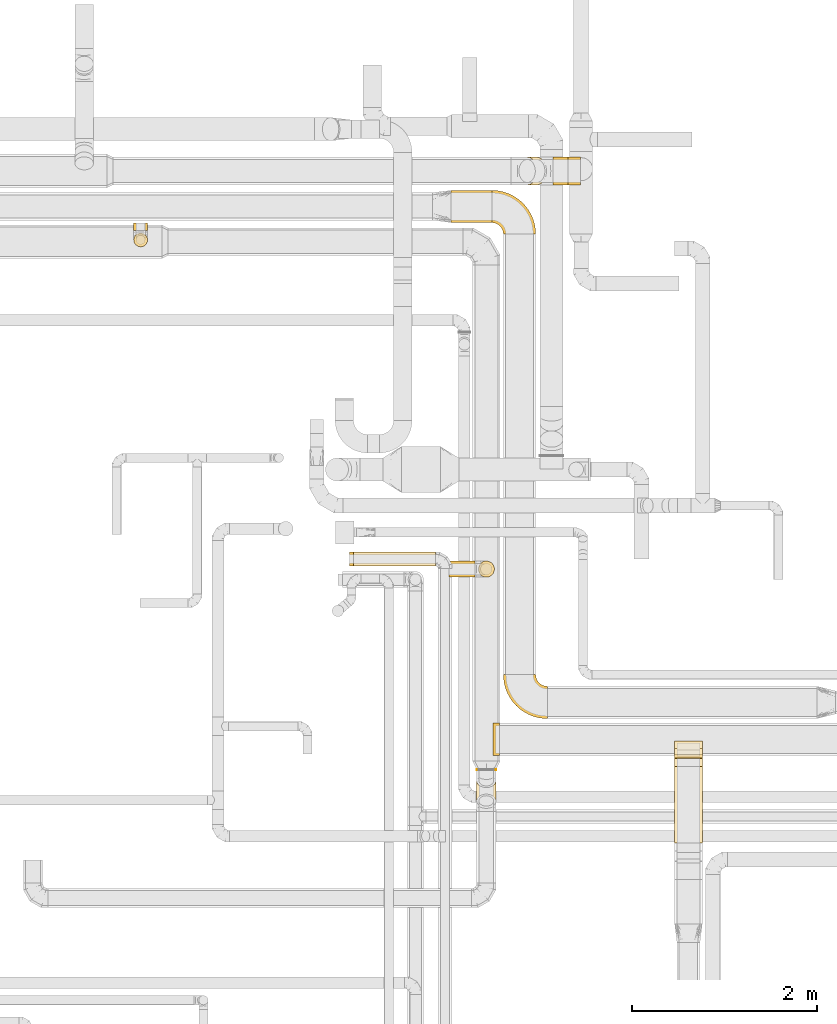
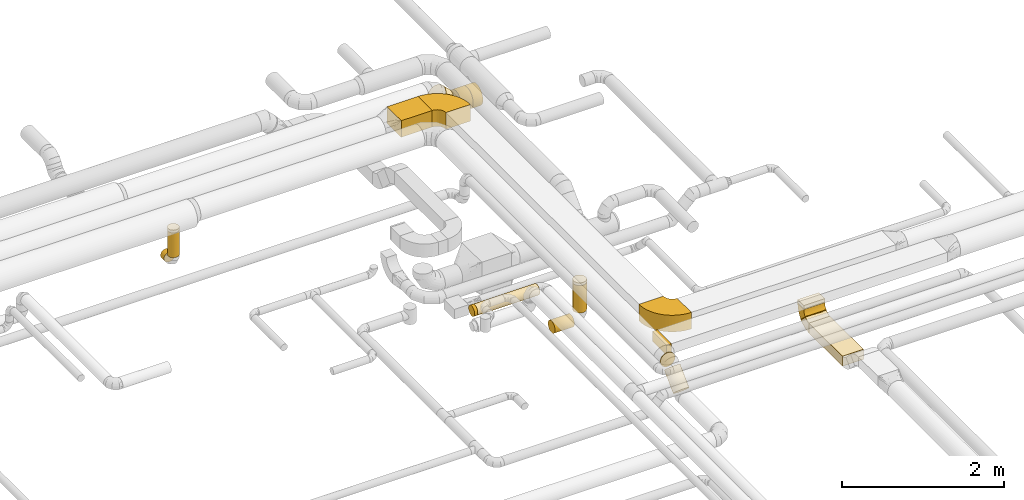
# One storey, part 5 of 92: 23 coverings.
"""IFC2X3 building model written with IfcOpenShell, lengths in millimetres."""

from ifc_helpers import new_model, entity, si_unit, converted_unit, derived_unit, direction, frame, frame_2d, origin, origin_2d_with_axis, place, context, subcontext, project, spatial, polyline, circle_curve, parameter, trimmed, segment, composite_curve, rectangle, circle, outline, extrude, element, save


model = new_model("IFC2X3")

# Units and contexts
model_context = context("Model", 3, precision=0.01, world=origin(), true_north=direction((6.12303176911189e-17, 1.0)))
body_context = subcontext(model_context, "Body", "Model", "MODEL_VIEW")
ifc_project = project(units=[si_unit("LENGTHUNIT", "METRE", prefix="MILLI"), si_unit("AREAUNIT", "SQUARE_METRE"), si_unit("VOLUMEUNIT", "CUBIC_METRE"), converted_unit("PLANEANGLEUNIT", "DEGREE", entity("IfcRatioMeasure", 0.0174532925199433), si_unit("PLANEANGLEUNIT", "RADIAN"), dimensions=[0, 0, 0, 0, 0, 0, 0]), si_unit("MASSUNIT", "GRAM", prefix="KILO"), derived_unit("MASSDENSITYUNIT", [(si_unit("MASSUNIT", "GRAM", prefix="KILO"), 1), (si_unit("LENGTHUNIT", "METRE"), -3)]), derived_unit("MOMENTOFINERTIAUNIT", [(si_unit("LENGTHUNIT", "METRE"), 4)]), si_unit("TIMEUNIT", "SECOND"), si_unit("FREQUENCYUNIT", "HERTZ"), si_unit("THERMODYNAMICTEMPERATUREUNIT", "DEGREE_CELSIUS"), derived_unit("THERMALTRANSMITTANCEUNIT", [(si_unit("MASSUNIT", "GRAM", prefix="KILO"), 1), (si_unit("THERMODYNAMICTEMPERATUREUNIT", "KELVIN"), -1), (si_unit("TIMEUNIT", "SECOND"), -3)]), derived_unit("VOLUMETRICFLOWRATEUNIT", [(si_unit("LENGTHUNIT", "METRE"), 3), (si_unit("TIMEUNIT", "SECOND"), -1)]), derived_unit("MASSFLOWRATEUNIT", [(si_unit("MASSUNIT", "GRAM", prefix="KILO"), 1), (si_unit("TIMEUNIT", "SECOND"), -1)]), derived_unit("ROTATIONALFREQUENCYUNIT", [(si_unit("TIMEUNIT", "SECOND"), -1)]), si_unit("ELECTRICCURRENTUNIT", "AMPERE"), si_unit("ELECTRICVOLTAGEUNIT", "VOLT"), si_unit("POWERUNIT", "WATT"), si_unit("FORCEUNIT", "NEWTON", prefix="KILO"), si_unit("ILLUMINANCEUNIT", "LUX"), si_unit("LUMINOUSFLUXUNIT", "LUMEN"), si_unit("LUMINOUSINTENSITYUNIT", "CANDELA"), derived_unit("USERDEFINED", [(si_unit("MASSUNIT", "GRAM", prefix="KILO"), -1), (si_unit("LENGTHUNIT", "METRE"), -2), (si_unit("TIMEUNIT", "SECOND"), 3), (si_unit("LUMINOUSFLUXUNIT", "LUMEN"), 1)]), derived_unit("LINEARVELOCITYUNIT", [(si_unit("LENGTHUNIT", "METRE"), 1), (si_unit("TIMEUNIT", "SECOND"), -1)]), si_unit("PRESSUREUNIT", "PASCAL"), derived_unit("USERDEFINED", [(si_unit("LENGTHUNIT", "METRE"), -2), (si_unit("MASSUNIT", "GRAM", prefix="KILO"), 1), (si_unit("TIMEUNIT", "SECOND"), -2)]), derived_unit("LINEARFORCEUNIT", [(si_unit("MASSUNIT", "GRAM", prefix="KILO"), 1), (si_unit("LENGTHUNIT", "METRE"), 1), (si_unit("TIMEUNIT", "SECOND"), -2), (si_unit("LENGTHUNIT", "METRE"), -1)]), derived_unit("PLANARFORCEUNIT", [(si_unit("MASSUNIT", "GRAM", prefix="KILO"), 1), (si_unit("LENGTHUNIT", "METRE"), 1), (si_unit("TIMEUNIT", "SECOND"), -2), (si_unit("LENGTHUNIT", "METRE"), -2)])], contexts=[model_context])

# Site, building, storey
site_placement = place(None, origin())
site = spatial("IfcSite", under=ifc_project, at=site_placement, CompositionType="ELEMENT")
building_placement = place(site_placement, origin())
building = spatial("IfcBuilding", under=site, at=building_placement, CompositionType="ELEMENT")
storey_placement = place(building_placement, frame((0.0, 0.0, 4200.0)))
storey = spatial("IfcBuildingStorey", under=building, at=storey_placement, CompositionType="ELEMENT", Elevation=4200.0)

# Coverings
covering_1_placement = place(storey_placement, frame((60704.33, 15163.51, 3175.0)))
element("IfcCovering", 1, at=covering_1_placement, inside=storey, PredefinedType="INSULATION", context=body_context, shape_type="SweptSolid", body=[
    extrude(rectangle(XDim=440.000000000013, YDim=349.999999999998, at=origin_2d_with_axis()), frame((220.0, 175.0, 0.0), z_axis=(0.0, 0.0, 1.0), x_axis=(-1.0, 0.0, 0.0)), (0.0, 0.0, 1.0), 249.999999999999),
])
covering_2_placement = place(storey_placement, frame((61806.89, 15570.41, 2848.4)))
element("IfcCovering", 2, at=covering_2_placement, inside=storey, PredefinedType="INSULATION", context=body_context, shape_type="SweptSolid", body=[
    extrude(circle(Radius=150.0, at=origin_2d_with_axis()), frame((0.0, 151.6, 151.6), z_axis=(1.0, 0.0, 0.0), x_axis=(0.0, -1.0, 0.0)), (0.0, 0.0, 1.0), 159.717263995072),
])
covering_3_placement = place(storey_placement, frame((61418.9, 15570.41, 2965.56)))
element("IfcCovering", 3, at=covering_3_placement, inside=storey, PredefinedType="INSULATION", context=body_context, shape_type="SweptSolid", body=[
    extrude(circle(Radius=150.0, at=origin_2d_with_axis()), frame((107.66, 151.6, 211.21), z_axis=(0.707106445676234, 0.0, -0.707107116696702), x_axis=(0.0, 1.0, 0.0)), (0.0, 0.0, 1.0), 146.446302678894),
])
covering_4_placement = place(storey_placement, frame((61966.61, 15570.41, 2848.4)))
element("IfcCovering", 4, at=covering_4_placement, inside=storey, PredefinedType="INSULATION", context=body_context, shape_type="SweptSolid", body=[
    extrude(circle(Radius=150.0, at=origin_2d_with_axis()), frame((0.0, 151.6, 151.6), z_axis=(1.0, 0.0, 0.0), x_axis=(0.0, 0.0, -1.0)), (0.0, 0.0, 1.0), 138.903999999999),
])
covering_5_placement = place(storey_placement, frame((57270.37, 15077.0, 2523.4)))
element("IfcCovering", 5, at=covering_5_placement, inside=storey, PredefinedType="INSULATION", context=body_context, shape_type="SweptSolid", body=[
    extrude(circle(Radius=75.0, at=origin_2d_with_axis()), frame((76.6, 0.0, 76.6), z_axis=(0.0, 1.0, 0.0), x_axis=(-1.0, 0.0, 0.0)), (0.0, 0.0, 1.0), 84.9999999999027),
])
covering_6_placement = place(storey_placement, frame((60683.72, 11327.66, 2510.9)))
element("IfcCovering", 6, at=covering_6_placement, inside=storey, PredefinedType="INSULATION", context=body_context, shape_type="SweptSolid", body=[
    extrude(circle(Radius=87.5, at=origin_2d_with_axis()), frame((0.0, 89.1, 89.1), z_axis=(1.0, 0.0, 0.0), x_axis=(0.0, 1.0, 0.0)), (0.0, 0.0, 1.0), 276.27551312413),
])
covering_7_placement = place(storey_placement, frame((60995.9, 11327.66, 2725.0)))
element("IfcCovering", 7, at=covering_7_placement, inside=storey, PredefinedType="INSULATION", context=body_context, shape_type="SweptSolid", body=[
    extrude(circle(Radius=87.5, at=origin_2d_with_axis()), frame((89.1, 89.1, 0.0), z_axis=(0.0, 0.0, 1.0), x_axis=(0.0, 1.0, 0.0)), (0.0, 0.0, 1.0), 412.500000000017),
])
covering_8_placement = place(storey_placement, frame((60995.9, 11327.66, 3137.5)))
element("IfcCovering", 8, at=covering_8_placement, inside=storey, PredefinedType="INSULATION", context=body_context, shape_type="SweptSolid", body=[
    extrude(circle(Radius=87.5, at=origin_2d_with_axis()), frame((89.1, 89.1, 0.0), z_axis=(0.0, 0.0, 1.0), x_axis=(0.0, 1.0, 0.0)), (0.0, 0.0, 1.0), 42.8428245269404),
])
covering_9_placement = place(storey_placement, frame((61159.11, 9400.17, 3225.0)))
element("IfcCovering", 9, at=covering_9_placement, inside=storey, PredefinedType="INSULATION", context=body_context, shape_type="SweptSolid", body=[
    extrude(rectangle(XDim=69.6568108823519, YDim=349.999999999999, at=origin_2d_with_axis()), frame((34.83, 175.0, 0.0), z_axis=(0.0, 0.0, 1.0), x_axis=(-1.0, 0.0, 0.0)), (0.0, 0.0, 1.0), 150.000000000001),
])
covering_10_placement = place(storey_placement, frame((57270.37, 14900.4, 2700.0)))
element("IfcCovering", 10, at=covering_10_placement, inside=storey, PredefinedType="INSULATION", context=body_context, shape_type="SweptSolid", body=[
    extrude(circle(Radius=75.0, at=origin_2d_with_axis()), frame((76.6, 76.6, 0.0), z_axis=(0.0, 0.0, 1.0), x_axis=(-1.0, 0.0, 0.0)), (0.0, 0.0, 1.0), 373.77500200031),
])
covering_11_placement = place(storey_placement, frame((63121.35, 8456.55, 2945.0)))
element("IfcCovering", 11, at=covering_11_placement, inside=storey, PredefinedType="INSULATION", context=body_context, shape_type="SweptSolid", body=[
    extrude(rectangle(XDim=825.783728094219, YDim=300.000000000001, at=origin_2d_with_axis()), frame((150.0, 412.89, 0.0), z_axis=(0.0, 0.0, 1.0), x_axis=(0.0, 1.0, 0.0)), (0.0, 0.0, 1.0), 150.000000000001),
])
covering_12_placement = place(storey_placement, frame((60978.4, 9241.69, 3175.9)))
element("IfcCovering", 12, at=covering_12_placement, inside=storey, PredefinedType="INSULATION", context=body_context, shape_type="SweptSolid", body=[
    extrude(circle(Radius=105.0, at=origin_2d_with_axis()), frame((106.6, 0.0, 106.6), z_axis=(0.0, 1.0, 0.0), x_axis=(1.0, 0.0, 0.0)), (0.0, 0.0, 1.0), 9.44565002031431),
])
covering_13_placement = place(storey_placement, frame((60978.4, 8833.94, 2941.02)))
element("IfcCovering", 13, at=covering_13_placement, inside=storey, PredefinedType="INSULATION", context=body_context, shape_type="SweptSolid", body=[
    extrude(circle(Radius=105.0, at=origin_2d_with_axis()), frame((106.6, 75.84, 75.84), z_axis=(0.0, 0.707106781186505, 0.707106781186591), x_axis=(1.0, 0.0, 0.0)), (0.0, 0.0, 1.0), 309.393398282201),
])
covering_14_placement = place(storey_placement, frame((63121.35, 9410.17, 3222.84)))
element("IfcCovering", 14, at=covering_14_placement, inside=storey, PredefinedType="INSULATION", context=body_context, shape_type="SweptSolid", body=[
    extrude(rectangle(XDim=300.000000000001, YDim=150.000000000001, at=origin_2d_with_axis()), frame((150.0, 75.0, 0.0), z_axis=(0.0, 0.0, 1.0), x_axis=(-1.0, 0.0, 0.0)), (0.0, 0.0, 1.0), 7.15728752542948),
])
covering_15_placement = place(storey_placement, frame((63121.35, 9410.17, 3230.0)))
element("IfcCovering", 15, at=covering_15_placement, inside=storey, PredefinedType="INSULATION", context=body_context, shape_type="SweptSolid", body=[
    extrude(rectangle(XDim=150.000000000001, YDim=300.000000000001, at=origin_2d_with_axis()), frame((150.0, 75.0, 0.0), z_axis=(0.0, 0.0, 1.0), x_axis=(0.0, -1.0, 0.0)), (0.0, 0.0, 1.0), 51.0960000000005),
])
covering_16_placement = place(storey_placement, frame((63121.35, 9370.72, 3025.55)))
element("IfcCovering", 16, at=covering_16_placement, inside=storey, PredefinedType="INSULATION", context=body_context, shape_type="SweptSolid", body=[
    extrude(rectangle(XDim=149.999999999999, YDim=4.02020253560479, at=frame_2d((0.0, 0.0), x_axis=(0.0, 1.0))), frame((0.0, 54.45, 54.45), z_axis=(1.0, 0.0, 0.0), x_axis=(0.0, 0.707106781190723, 0.707106781182372)), (0.0, 0.0, 1.0), 300.000000000001),
])
covering_17_placement = place(storey_placement, frame((57270.37, 14900.4, 3073.78)))
element("IfcCovering", 17, at=covering_17_placement, inside=storey, PredefinedType="INSULATION", context=body_context, shape_type="SweptSolid", body=[
    extrude(circle(Radius=75.0, at=origin_2d_with_axis()), frame((76.6, 76.6, 0.0)), (0.0, 0.0, 1.0), 41.2314874044464),
])
covering_18_placement = place(storey_placement, frame((59650.81, 11448.3, 3073.4)))
element("IfcCovering", 18, at=covering_18_placement, inside=storey, PredefinedType="INSULATION", context=body_context, shape_type="SweptSolid", body=[
    extrude(circle(Radius=75.0, at=origin_2d_with_axis()), frame((0.0, 76.6, 76.6), z_axis=(1.0, 0.0, 0.0), x_axis=(0.0, -1.0, 0.0)), (0.0, 0.0, 1.0), 886.324534692973),
])
covering_19_placement = place(storey_placement, frame((59607.15, 11448.3, 3073.4)))
element("IfcCovering", 19, at=covering_19_placement, inside=storey, PredefinedType="INSULATION", context=body_context, shape_type="SweptSolid", body=[
    extrude(circle(Radius=75.0, at=origin_2d_with_axis()), frame((0.0, 76.6, 76.6), z_axis=(1.0, 0.0, 0.0), x_axis=(0.0, 0.0, -1.0)), (0.0, 0.0, 1.0), 43.6560447779815),
])
covering_20_placement = place(storey_placement, frame((61267.74, 9798.33, 3175.0)))
element("IfcCovering", 20, at=covering_20_placement, inside=storey, PredefinedType="INSULATION", context=body_context, shape_type="SweptSolid", body=[
    extrude(outline(composite_curve([segment(polyline([(-150.0, 25.0), (-150.0, -325.0)]), True, "CONTINUOUS"), segment(trimmed(circle_curve(frame_2d((-150.0, 150.0), x_axis=(1.0, 0.0)), 475.0), [parameter(270.0)], [parameter(0.0)], True, "PARAMETER"), True, "CONTINUOUS"), segment(polyline([(325.0, 150.0), (-25.0, 150.0)]), True, "CONTINUOUS"), segment(trimmed(circle_curve(frame_2d((-150.0, 150.0), x_axis=(1.0, 0.0)), 125.0), [parameter(270.0)], [parameter(360.0)], True, "PARAMETER"), False, "CONTINUOUS")], self_intersect=False)), frame((326.6, 326.6, 0.0), z_axis=(0.0, 0.0, -1.0), x_axis=(-1.0, 0.0, 0.0)), (0.0, 0.0, -1.0), 249.999999999999),
])
covering_21_placement = place(storey_placement, frame((61142.74, 15036.91, 3175.0)))
element("IfcCovering", 21, at=covering_21_placement, inside=storey, PredefinedType="INSULATION", context=body_context, shape_type="SweptSolid", body=[
    extrude(outline(composite_curve([segment(polyline([(-150.0, 25.0), (-150.0, -325.0)]), True, "CONTINUOUS"), segment(trimmed(circle_curve(frame_2d((-150.0, 150.0), x_axis=(1.0, 0.0)), 475.0), [parameter(270.0)], [parameter(0.0)], True, "PARAMETER"), True, "CONTINUOUS"), segment(polyline([(325.0, 150.0), (-25.0, 150.0)]), True, "CONTINUOUS"), segment(trimmed(circle_curve(frame_2d((-150.0, 150.0), x_axis=(1.0, 0.0)), 125.0), [parameter(270.0)], [parameter(360.0)], True, "PARAMETER"), False, "CONTINUOUS")], self_intersect=False)), frame((151.6, 151.6, 0.0), z_axis=(0.0, 0.0, -1.0), x_axis=(1.0, 0.0, 0.0)), (0.0, 0.0, -1.0), 249.999999999999),
])
covering_22_placement = place(storey_placement, frame((63121.35, 9280.74, 2943.4)))
element("IfcCovering", 22, at=covering_22_placement, inside=storey, PredefinedType="INSULATION", context=body_context, shape_type="SweptSolid", body=[
    extrude(outline(composite_curve([segment(polyline([(-82.32, -17.68), (23.74, -123.74)]), True, "CONTINUOUS"), segment(trimmed(circle_curve(frame_2d((-170.71, 70.71), x_axis=(1.0, 0.0)), 275.0), [parameter(315.0)], [parameter(0.0)], True, "PARAMETER"), True, "CONTINUOUS"), segment(polyline([(104.29, 70.71), (-45.71, 70.71)]), True, "CONTINUOUS"), segment(trimmed(circle_curve(frame_2d((-170.71, 70.71), x_axis=(1.0, 0.0)), 125.0), [parameter(315.0)], [parameter(360.0)], True, "PARAMETER"), False, "CONTINUOUS")], self_intersect=False)), frame((0.0, 72.31, 105.88), z_axis=(-1.0, 0.0, 0.0), x_axis=(0.0, 0.0, -1.0)), (0.0, 0.0, -1.0), 300.000000000001),
])
covering_23_placement = place(storey_placement, frame((63121.35, 9371.97, 3026.79)))
element("IfcCovering", 23, at=covering_23_placement, inside=storey, PredefinedType="INSULATION", context=body_context, shape_type="SweptSolid", body=[
    extrude(outline(composite_curve([segment(polyline([(-45.71, -70.71), (104.29, -70.71)]), True, "CONTINUOUS"), segment(trimmed(circle_curve(frame_2d((-170.71, -70.71), x_axis=(0.707106781186546, 0.707106781186553)), 275.0), [parameter(315.0)], [parameter(0.0)], True, "PARAMETER"), True, "CONTINUOUS"), segment(polyline([(23.74, 123.74), (-82.32, 17.68)]), True, "CONTINUOUS"), segment(trimmed(circle_curve(frame_2d((-170.71, -70.71), x_axis=(0.707106781186546, 0.707106781186553)), 125.0), [parameter(315.0)], [parameter(360.0)], True, "PARAMETER"), False, "CONTINUOUS")], self_intersect=False)), frame((0.0, 83.92, 125.34), z_axis=(1.0, 0.0, 0.0), x_axis=(0.0, 0.707106781186548, -0.707106781186548)), (0.0, 0.0, 1.0), 300.000000000001),
])

save(model, "model.ifc")
